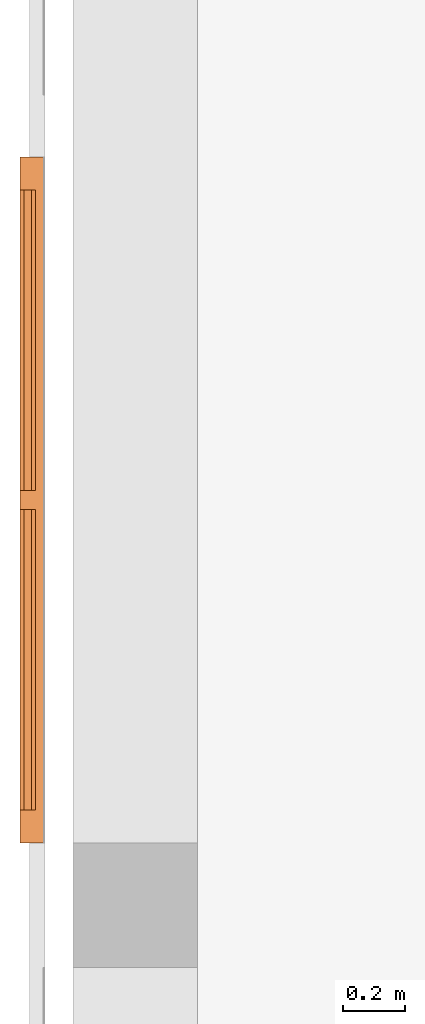
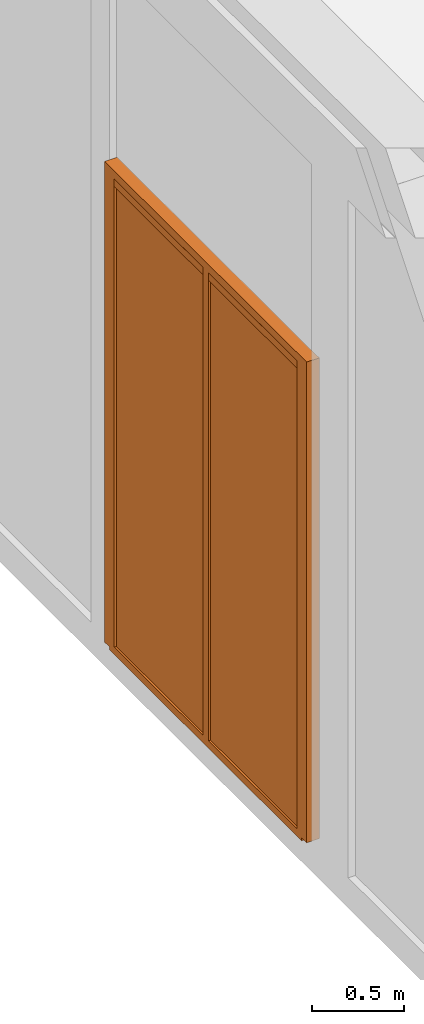
# One storey, part 5 of 5: 5 proxies, 1 element without a shape of its own.
"""IFC2X3 building model written with IfcOpenShell, lengths in metres."""

import ifcopenshell
import ifcopenshell.guid

model = None  # the IFC model being written
_history = None  # IfcOwnerHistory: only IFC2X3 demands one
_inside = {}  # id of a spatial element -> (the spatial element, [elements in it])
_under = {}  # id of a project, library or spatial element -> (it, [spatial elements below it])
_declared = {}  # id of a project -> (the project, [libraries it declares])
_typed = {}  # id of a type object -> (the type object, [elements of that type])
_made_of = {}  # id of a material, layer set ... -> (it, [elements and type objects made of it])


def new_model(schema):
    """Start an empty IFC model of exactly this schema.

    Asked for "IFC4X3", IfcOpenShell would pick the latest addendum, in which some entities
    have other attributes; the version numbers below select the first issue.
    IFC2X3 requires an IfcOwnerHistory on every rooted entity: one is made here for all.
    """
    global model, _history
    if schema == "IFC4X3":
        model = ifcopenshell.file(schema_version=(4, 3, 0, 0))
    else:
        model = ifcopenshell.file(schema=schema)
    _inside.clear()
    _under.clear()
    _declared.clear()
    _typed.clear()
    _made_of.clear()
    _history = None
    if model.schema == "IFC2X3":
        org = make("IfcOrganization", Name="unknown")
        user = make(
            "IfcPersonAndOrganization",
            ThePerson=make("IfcPerson", FamilyName="unknown"),
            TheOrganization=org,
        )
        app = make(
            "IfcApplication",
            ApplicationDeveloper=org,
            Version="unknown",
            ApplicationFullName="unknown",
            ApplicationIdentifier="unknown",
        )
        _history = make(
            "IfcOwnerHistory",
            OwningUser=user,
            OwningApplication=app,
            ChangeAction="ADDED",
            CreationDate=0,
        )
    return model


def make(cls, **values):
    """One entity of the class cls with the attributes given. An attribute that is None is left unset."""
    return model.create_entity(
        cls, **{name: value for name, value in values.items() if value is not None}
    )


def entity(cls, *values):
    """Any entity or typed value of the class cls, its attributes in the order of the schema. None: left unset."""
    e = model.create_entity(cls)
    for i, value in enumerate(values):
        if value is not None:
            e[i] = value
    return e


def rooted(cls, **values):
    """An entity with a GlobalId (a new one), such as an element, a storey or a relation."""
    return make(cls, GlobalId=ifcopenshell.guid.new(), OwnerHistory=_history, **values)


def si_unit(unit_type, name, prefix=None):
    """IfcSIUnit, for example si_unit("LENGTHUNIT", "METRE", prefix="MILLI")."""
    return make("IfcSIUnit", UnitType=unit_type, Prefix=prefix, Name=name)


def converted_unit(unit_type, name, factor, base, dimensions=None, offset=None):
    """IfcConversionBasedUnit, such as the inch: factor (a typed value) times the base unit."""
    return make(
        "IfcConversionBasedUnit"
        if offset is None
        else "IfcConversionBasedUnitWithOffset",
        ConversionOffset=offset,
        Dimensions=None
        if dimensions is None
        else entity("IfcDimensionalExponents", *dimensions),
        UnitType=unit_type,
        Name=name,
        ConversionFactor=make(
            "IfcMeasureWithUnit", ValueComponent=factor, UnitComponent=base
        ),
    )


def assignment(units):
    """IfcUnitAssignment: the units of a project."""
    return None if units is None else make("IfcUnitAssignment", Units=units)


def point(xyz):
    """IfcCartesianPoint."""
    return None if xyz is None else make("IfcCartesianPoint", Coordinates=xyz)


def direction(xyz):
    """IfcDirection."""
    return None if xyz is None else make("IfcDirection", DirectionRatios=xyz)


def frame(location, z_axis=None, x_axis=None):
    """IfcAxis2Placement3D, a coordinate frame: its origin and axes. An axis left out is left unset."""
    return make(
        "IfcAxis2Placement3D",
        Location=point(location),
        Axis=direction(z_axis),
        RefDirection=direction(x_axis),
    )


def origin():
    """The frame at (0, 0, 0) with its axes left unset."""
    return frame((0.0, 0.0, 0.0))


def place(relative_to, where):
    """IfcLocalPlacement: puts the frame where relative to a parent placement (None: the world)."""
    return make(
        "IfcLocalPlacement", PlacementRelTo=relative_to, RelativePlacement=where
    )


def context(
    kind, dimensions, precision=None, world=None, true_north=None, identifier=None
):
    """IfcGeometricRepresentationContext, for example the 3D "Model" context."""
    return make(
        "IfcGeometricRepresentationContext",
        ContextIdentifier=identifier,
        ContextType=kind,
        CoordinateSpaceDimension=dimensions,
        Precision=precision,
        WorldCoordinateSystem=world,
        TrueNorth=true_north,
    )


def subcontext(parent, identifier, kind, view, scale=None):
    """IfcGeometricRepresentationSubContext, for example "Body" below "Model"."""
    return make(
        "IfcGeometricRepresentationSubContext",
        ContextIdentifier=identifier,
        ContextType=kind,
        ParentContext=parent,
        TargetScale=scale,
        TargetView=view,
    )


def project(units=None, contexts=None):
    """IfcProject with its units and contexts."""
    return rooted(
        "IfcProject",
        Name="project",
        RepresentationContexts=contexts,
        UnitsInContext=assignment(units),
    )


def spatial(cls, under=None, at=None, **own):
    """A site, building, storey or space (cls), placed at a placement, below another one or the project."""
    s = rooted(cls, ObjectPlacement=at, **own)
    if under is not None:
        _under.setdefault(under.id(), (under, []))[1].append(s)
    return s


def faces_of(points, faces, orient=None, outer=None):
    """IfcFace entities. A face is a list of loops; a loop is a list of indices into points, from 0.

    orient and outer hold one flag for each loop. By default every Orientation is true, the
    first loop of a face is its IfcFaceOuterBound and the others are IfcFaceBound.
    """
    made = []
    for i, loops in enumerate(faces):
        bounds = []
        for j, loop in enumerate(loops):
            is_outer = j == 0 if outer is None else outer[i][j]
            bounds.append(
                make(
                    "IfcFaceOuterBound" if is_outer else "IfcFaceBound",
                    Bound=make("IfcPolyLoop", Polygon=[points[k] for k in loop]),
                    Orientation=True if orient is None else orient[i][j],
                )
            )
        made.append(make("IfcFace", Bounds=bounds))
    return made


def faceted_brep(points, faces, orient=None, outer=None, voids=None):
    """IfcFacetedBrep: a solid bounded by flat faces; with voids (closed shells), ...WithVoids."""
    shared = [point(p) for p in points]
    hull = make("IfcClosedShell", CfsFaces=faces_of(shared, faces, orient, outer))
    if voids is None:
        return make("IfcFacetedBrep", Outer=hull)
    return make(
        "IfcFacetedBrepWithVoids",
        Outer=hull,
        Voids=[
            make(cls, CfsFaces=faces_of(shared, fs, o, b)) for cls, fs, o, b in voids
        ],
    )


def shape(context_of_items, identifier, shape_type, items):
    """IfcShapeRepresentation: the items that make up one representation, for example the "Body"."""
    return make(
        "IfcShapeRepresentation",
        ContextOfItems=context_of_items,
        RepresentationIdentifier=identifier,
        RepresentationType=shape_type,
        Items=items,
    )


def material(Name=None, Category=None):
    """IfcMaterial."""
    return make("IfcMaterial", Name=Name, Category=Category)


def made_of(thing, what):
    """Note that an element or type object is made of a material, layer set ...; save() writes the relation."""
    if what is not None:
        _made_of.setdefault(what.id(), (what, []))[1].append(thing)
    return thing


def element(
    cls,
    number,
    at=None,
    inside=None,
    cuts=None,
    type_object=None,
    material=None,
    context=None,
    identifier="Body",
    shape_type=None,
    held_by="IfcProductDefinitionShape",
    body=None,
    shapes=None,
    **own,
):
    """One element of the class cls, such as IfcWall. Its Tag is "e" and its number.

    at: its placement. inside: the storey or other place that contains it. cuts: it is an
    opening in that element (IfcRelVoidsElement). A single representation is given by context,
    identifier, shape_type and body (its items); several are given by shapes. held_by: the class
    of the entity that holds the representations. save() writes the other relations.
    """
    e = rooted(cls, Tag="e%d" % number, ObjectPlacement=at, **own)
    if body is not None:
        shapes = [shape(context, identifier, shape_type, body)]
    if shapes is not None:
        e.Representation = make(held_by, Representations=shapes)
    if inside is not None:
        _inside.setdefault(inside.id(), (inside, []))[1].append(e)
    if cuts is not None:
        rooted(
            "IfcRelVoidsElement", RelatingBuildingElement=cuts, RelatedOpeningElement=e
        )
    if type_object is not None:
        _typed.setdefault(type_object.id(), (type_object, []))[1].append(e)
    return made_of(e, material)


def aggregate(whole, parts):
    """IfcRelAggregates: a whole, such as a stair, and the parts it consists of."""
    return rooted("IfcRelAggregates", RelatingObject=whole, RelatedObjects=parts)


def save(model, path):
    """Write the relations noted so far, then the file.

    IfcRelAggregates (storeys below a building ...), IfcRelContainedInSpatialStructure (elements
    in a storey), IfcRelDefinesByType, IfcRelAssociatesMaterial and IfcRelDeclares: one each for
    every whole, place, type object, material and project.
    """
    for whole, parts in _under.values():
        aggregate(whole, parts)
    for where, things in _inside.values():
        rooted(
            "IfcRelContainedInSpatialStructure",
            RelatedElements=things,
            RelatingStructure=where,
        )
    for kind, things in _typed.values():
        rooted("IfcRelDefinesByType", RelatedObjects=things, RelatingType=kind)
    for what, things in _made_of.values():
        rooted("IfcRelAssociatesMaterial", RelatedObjects=things, RelatingMaterial=what)
    for by, libraries in _declared.values():
        rooted("IfcRelDeclares", RelatingContext=by, RelatedDefinitions=libraries)
    model.write(path)


model = new_model("IFC2X3")

# Units and contexts
model_context = context("Model", 3, precision=1e-05, world=origin())
body_context = subcontext(model_context, "Body", "Model", "MODEL_VIEW")
ifc_project = project(units=[si_unit("LENGTHUNIT", "METRE"), si_unit("AREAUNIT", "SQUARE_METRE"), si_unit("VOLUMEUNIT", "CUBIC_METRE"), si_unit("MASSUNIT", "GRAM", prefix="KILO"), converted_unit("PLANEANGLEUNIT", "DEGREE", entity("IfcPlaneAngleMeasure", 0.0174532925199433), si_unit("PLANEANGLEUNIT", "RADIAN"), dimensions=[0, 0, 0, 0, 0, 0, 0])], contexts=[model_context])

# Site, building, storey
site_placement = place(None, origin())
site = spatial("IfcSite", under=ifc_project, at=site_placement, CompositionType="ELEMENT")
building_placement = place(site_placement, origin())
building = spatial("IfcBuilding", under=site, at=building_placement, CompositionType="ELEMENT")
storey_placement = place(building_placement, frame((0.0, 0.0, -0.2)))
storey = spatial("IfcBuildingStorey", under=building, at=storey_placement, Name="Erdgeschoss", CompositionType="ELEMENT", Elevation=-0.2)

# Assembly, proxies
assembly_placement = place(storey_placement, frame((0.0, 0.0, 0.2)))
assembly = element("IfcElementAssembly", 1, at=assembly_placement, inside=storey, PredefinedType="NOTDEFINED")
ifc_material_1 = material()
proxy_1_placement = place(storey_placement, frame((-0.169330706017222, 6.53049999999999, 3.09)))
proxy_1 = element("IfcBuildingElementProxy", 2, at=proxy_1_placement, material=ifc_material_1, context=body_context, shape_type="Brep", body=[
    faceted_brep([(0.05, 0.9645, 0.05), (0.05, 0.9645, 0.0), (0.0500000000000001, 0.0, 0.0), (0.0500000000000001, 0.0, 0.05), (0.0, 0.9645, 0.0), (0.0, 0.9645, 0.05), (1.13686837721616e-16, 0.0, 0.05), (1.13686837721616e-16, 0.0, 0.0)], [[[0, 1, 2, 3]], [[4, 5, 6, 7]], [[1, 0, 5, 4]], [[2, 1, 4, 7]], [[3, 2, 7, 6]], [[0, 3, 6, 5]]], orient=[[False], [False], [False], [False], [False], [False]]),
])
ifc_material_2 = material()
proxy_2_placement = place(storey_placement, frame((-0.169330706017222, 5.50499999999999, 3.09)))
proxy_2 = element("IfcBuildingElementProxy", 3, at=proxy_2_placement, material=ifc_material_2, context=body_context, shape_type="Brep", body=[
    faceted_brep([(0.05, 0.964499999999999, 0.05), (0.05, 0.964499999999999, 0.0), (0.0500000000000002, 0.0, 0.0), (0.0500000000000002, 0.0, 0.05), (2.8421709430404e-17, 0.964499999999999, 0.0), (5.6843418860808e-17, 0.964499999999999, 0.05), (1.70530256582424e-16, 0.0, 0.05), (1.70530256582424e-16, 0.0, 0.0)], [[[0, 1, 2, 3]], [[4, 5, 6, 7]], [[1, 0, 5, 4]], [[2, 1, 4, 7]], [[3, 2, 7, 6]], [[0, 3, 6, 5]]], orient=[[False], [False], [False], [False], [False], [False]]),
])
ifc_material_3 = material(Name="Alu")
proxy_3_placement = place(storey_placement, frame((-0.169330706017223, 5.39999999999999, -0.0200000000000005)))
proxy_3 = element("IfcBuildingElementProxy", 4, at=proxy_3_placement, material=ifc_material_3, context=body_context, shape_type="Brep", body=[
    faceted_brep([(0.0, 2.145, 0.0), (0.05, 2.145, 0.0), (0.0499999999999995, 2.145, 0.0200000000000005), (0.0, 2.145, 0.0200000000000005), (4.54747350886464e-16, 0.055, 0.0), (0.0500000000000005, 0.055, 0.0), (4.54747350886464e-16, 0.055, 0.0200000000000005), (0.0499999999999995, 0.055, 0.0200000000000005), (4.54747350886464e-16, 0.105, 0.0500000000000005), (0.0500000000000005, 0.105, 0.0500000000000005), (0.0500000000000005, 0.105, 3.14), (4.54747350886464e-16, 0.105, 3.14), (0.05, 1.0695, 0.0500000000000005), (0.0, 1.0695, 0.0500000000000005), (4.54747350886464e-16, 1.0695, 3.14), (0.05, 1.0695, 3.14), (0.0, 1.1305, 0.0500000000000005), (0.05, 1.1305, 0.0500000000000005), (0.0500000000000005, 1.1305, 3.14), (4.54747350886464e-16, 1.1305, 3.14), (0.05, 2.095, 0.0500000000000005), (0.0, 2.095, 0.0500000000000005), (4.54747350886464e-16, 2.095, 3.14), (0.05, 2.095, 3.14), (0.05, 0.075, 3.14), (0.0800000000000005, 0.075, 3.14), (0.0800000000000005, 2.125, 3.14), (0.05, 2.125, 3.14), (0.05, 0.075, 0.0200000000000005), (0.0800000000000005, 0.075, 0.0200000000000005), (4.54747350886464e-16, 0.0, 0.0200000000000005), (0.0800000000000005, 0.0, 0.0200000000000005), (0.0800000000000005, 0.0, 3.215), (4.54747350886464e-16, 0.0, 3.215), (0.0499999999999995, 2.125, 0.0200000000000005), (0.08, 2.2, 0.0200000000000005), (0.0800000000000005, 2.2, 3.215), (4.54747350886464e-16, 2.2, 3.215), (0.0, 2.2, 0.0200000000000005), (0.08, 2.125, 0.0200000000000005)], [[[0, 1, 2, 3]], [[1, 0, 4, 5]], [[5, 4, 6, 7]], [[8, 9, 10, 11]], [[12, 9, 8, 13]], [[12, 13, 14, 15]], [[16, 17, 18, 19]], [[20, 17, 16, 21]], [[20, 21, 22, 23]], [[22, 19, 18, 15, 14, 11, 10, 24, 25, 26, 27, 23]], [[28, 29, 25, 24]], [[6, 30, 31, 29, 28, 7]], [[32, 31, 30, 33]], [[2, 1, 5, 7, 28, 24, 10, 9, 12, 15, 18, 17, 20, 23, 27, 34]], [[35, 36, 37, 38]], [[2, 34, 39, 35, 38, 3]], [[26, 39, 34, 27]], [[36, 32, 33, 37]], [[36, 35, 39, 26, 25, 29, 31, 32]], [[38, 37, 33, 30, 6, 4, 0, 3], [14, 13, 8, 11], [22, 21, 16, 19]]], orient=[[False], [False], [False], [False], [False], [False], [False], [False], [False], [False], [False], [False], [False], [False], [False], [False], [False], [False], [False], [False, False, False]]),
])
ifc_material_4 = material(Name="Glas")
proxy_4_placement = place(storey_placement, frame((-0.156330706017223, 6.53049999999999, 0.03)))
proxy_4 = element("IfcBuildingElementProxy", 5, at=proxy_4_placement, material=ifc_material_4, context=body_context, shape_type="Brep", body=[
    faceted_brep([(0.0240000000000004, 0.9645, 3.06), (0.024, 0.9645, 0.0), (0.0240000000000001, 0.0, 0.0), (0.0240000000000005, 0.0, 3.06), (0.0, 0.9645, 0.0), (3.97903932025656e-16, 0.9645, 3.06), (5.11590769747272e-16, 0.0, 3.06), (1.4210854715202e-16, 0.0, 0.0)], [[[0, 1, 2, 3]], [[4, 5, 6, 7]], [[1, 0, 5, 4]], [[2, 1, 4, 7]], [[3, 2, 7, 6]], [[0, 3, 6, 5]]], orient=[[False], [False], [False], [False], [False], [False]]),
])
ifc_material_5 = material(Name="Glas")
proxy_5_placement = place(storey_placement, frame((-0.156330706017223, 5.50499999999999, 0.03)))
proxy_5 = element("IfcBuildingElementProxy", 6, at=proxy_5_placement, material=ifc_material_5, context=body_context, shape_type="Brep", body=[
    faceted_brep([(0.0240000000000004, 0.964499999999999, 3.06), (0.024, 0.964499999999999, 0.0), (0.0240000000000001, 0.0, 0.0), (0.0240000000000005, 0.0, 3.06), (0.0, 0.964499999999999, 0.0), (3.69482222595252e-16, 0.964499999999999, 3.06), (4.83169060316868e-16, 0.0, 3.06), (1.13686837721616e-16, 0.0, 0.0)], [[[0, 1, 2, 3]], [[4, 5, 6, 7]], [[1, 0, 5, 4]], [[2, 1, 4, 7]], [[3, 2, 7, 6]], [[0, 3, 6, 5]]], orient=[[False], [False], [False], [False], [False], [False]]),
])
aggregate(assembly, [proxy_1, proxy_2, proxy_3, proxy_4, proxy_5])

save(model, "model.ifc")
